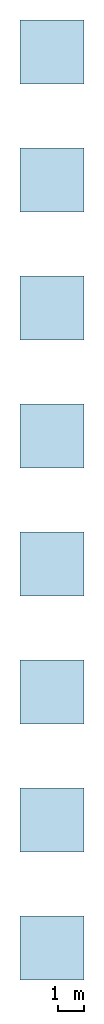
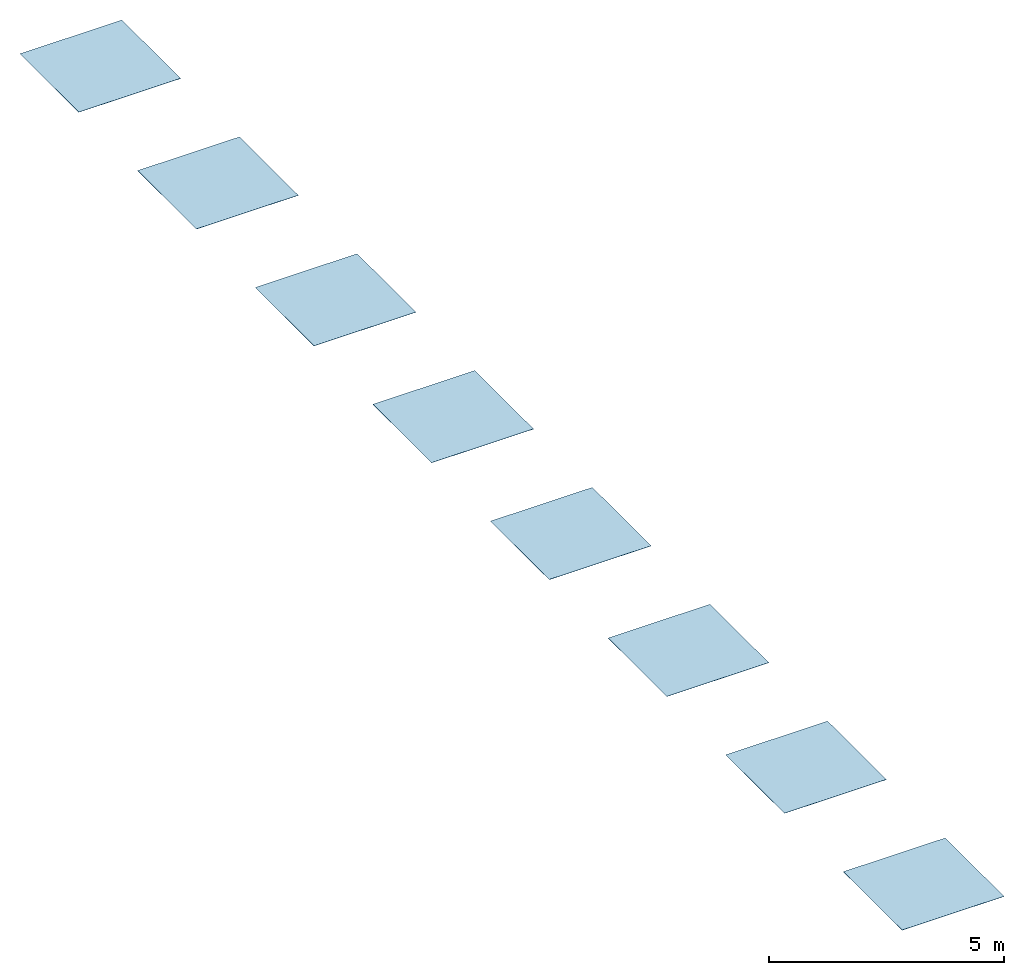
# Not in any storey: 8 slabs.
"""IFC2X3 building model written with IfcOpenShell, lengths in millimetres."""

from ifc_helpers import new_model, si_unit, frame, frame_2d, origin, origin_with_axes, origin_2d, place, context, project, spatial, rectangle, extrude, material, layer, layer_set, layer_usage, type_object, element, save


model = new_model("IFC2X3")

# Units and contexts
model_context = context("Model", 3, precision=1e-05, world=origin())
plan_context = context("Plan", 2, precision=1e-05, world=origin_2d())
ifc_project = project(units=[si_unit("LENGTHUNIT", "METRE", prefix="MILLI"), si_unit("AREAUNIT", "SQUARE_METRE"), si_unit("VOLUMEUNIT", "CUBIC_METRE"), si_unit("SOLIDANGLEUNIT", "STERADIAN"), si_unit("PLANEANGLEUNIT", "RADIAN"), si_unit("MASSUNIT", "GRAM"), si_unit("TIMEUNIT", "SECOND"), si_unit("THERMODYNAMICTEMPERATUREUNIT", "DEGREE_CELSIUS"), si_unit("LUMINOUSINTENSITYUNIT", "LUMEN")], contexts=[model_context, plan_context])

# Site, building
site_placement = place(None, frame((0.0, 0.0, 0.0), z_axis=(0.0, 1.0, 0.0), x_axis=(0.0, 0.0, 1.0)))
site = spatial("IfcSite", under=ifc_project, at=site_placement, CompositionType="ELEMENT")
building_placement = place(site_placement, frame((0.0, 0.0, 0.0), z_axis=(0.0, 1.0, 0.0), x_axis=(0.0, 0.0, 1.0)))
building = spatial("IfcBuilding", under=site, at=building_placement, Name="Default building", CompositionType="ELEMENT")

# Slabs
ifc_material_1 = material()
ifc_layer_1 = layer(ifc_material_1, 5.0, ventilated=False)
ifc_layer_set_1 = layer_set([ifc_layer_1])
ifc_layer_usage_1 = layer_usage(ifc_layer_set_1, "AXIS3", "NEGATIVE", 0.0)
slab_type_1 = type_object("IfcSlabType", PredefinedType="ROOF", material=ifc_layer_set_1)
slab_1_placement = place(None, origin())
element("IfcSlab", 1, at=slab_1_placement, inside=building, type_object=slab_type_1, material=ifc_layer_usage_1, PredefinedType="ROOF", context=model_context, shape_type="SweptSolid", body=[
    extrude(rectangle(XDim=2500.0, YDim=2500.0, at=frame_2d((1250.0, 1250.0))), origin_with_axes(), (0.0, 0.0, 1.0), 5.0),
])
ifc_material_2 = material()
ifc_layer_2 = layer(ifc_material_2, 5.0, ventilated=False)
ifc_layer_set_2 = layer_set([ifc_layer_2])
ifc_layer_usage_2 = layer_usage(ifc_layer_set_2, "AXIS3", "NEGATIVE", 0.0)
slab_type_2 = type_object("IfcSlabType", PredefinedType="ROOF", material=ifc_layer_set_2)
slab_2_placement = place(None, frame((0.0, 5000.0, 0.0)))
element("IfcSlab", 2, at=slab_2_placement, inside=building, type_object=slab_type_2, material=ifc_layer_usage_2, PredefinedType="ROOF", context=model_context, shape_type="SweptSolid", body=[
    extrude(rectangle(XDim=2500.0, YDim=2500.0, at=frame_2d((1250.0, 1250.0))), origin_with_axes(), (0.0, 0.0, 1.0), 5.0),
])
ifc_material_3 = material()
ifc_layer_3 = layer(ifc_material_3, 5.0, ventilated=False)
ifc_layer_set_3 = layer_set([ifc_layer_3])
ifc_layer_usage_3 = layer_usage(ifc_layer_set_3, "AXIS3", "NEGATIVE", 0.0)
slab_type_3 = type_object("IfcSlabType", PredefinedType="ROOF", material=ifc_layer_set_3)
slab_3_placement = place(None, frame((0.0, 10000.0, 0.0)))
element("IfcSlab", 3, at=slab_3_placement, inside=building, type_object=slab_type_3, material=ifc_layer_usage_3, PredefinedType="ROOF", context=model_context, shape_type="SweptSolid", body=[
    extrude(rectangle(XDim=2500.0, YDim=2500.0, at=frame_2d((1250.0, 1250.0))), origin_with_axes(), (0.0, 0.0, 1.0), 5.0),
])
ifc_material_4 = material()
ifc_layer_4 = layer(ifc_material_4, 5.0, ventilated=False)
ifc_layer_set_4 = layer_set([ifc_layer_4])
ifc_layer_usage_4 = layer_usage(ifc_layer_set_4, "AXIS3", "NEGATIVE", 0.0)
slab_type_4 = type_object("IfcSlabType", PredefinedType="ROOF", material=ifc_layer_set_4)
slab_4_placement = place(None, frame((0.0, 15000.0, 0.0)))
element("IfcSlab", 4, at=slab_4_placement, inside=building, type_object=slab_type_4, material=ifc_layer_usage_4, PredefinedType="ROOF", context=model_context, shape_type="SweptSolid", body=[
    extrude(rectangle(XDim=2500.0, YDim=2500.0, at=frame_2d((1250.0, 1250.0))), origin_with_axes(), (0.0, 0.0, 1.0), 5.0),
])
ifc_material_5 = material()
ifc_layer_5 = layer(ifc_material_5, 5.0, ventilated=False)
ifc_layer_set_5 = layer_set([ifc_layer_5])
ifc_layer_usage_5 = layer_usage(ifc_layer_set_5, "AXIS3", "NEGATIVE", 0.0)
slab_type_5 = type_object("IfcSlabType", PredefinedType="ROOF", material=ifc_layer_set_5)
slab_5_placement = place(None, frame((0.0, 20000.0, 0.0)))
element("IfcSlab", 5, at=slab_5_placement, inside=building, type_object=slab_type_5, material=ifc_layer_usage_5, PredefinedType="ROOF", context=model_context, shape_type="SweptSolid", body=[
    extrude(rectangle(XDim=2500.0, YDim=2500.0, at=frame_2d((1250.0, 1250.0))), origin_with_axes(), (0.0, 0.0, 1.0), 5.0),
])
ifc_material_6 = material()
ifc_layer_6 = layer(ifc_material_6, 5.0, ventilated=False)
ifc_layer_set_6 = layer_set([ifc_layer_6])
ifc_layer_usage_6 = layer_usage(ifc_layer_set_6, "AXIS3", "NEGATIVE", 0.0)
slab_type_6 = type_object("IfcSlabType", PredefinedType="ROOF", material=ifc_layer_set_6)
slab_6_placement = place(None, frame((0.0, 25000.0, 0.0)))
element("IfcSlab", 6, at=slab_6_placement, inside=building, type_object=slab_type_6, material=ifc_layer_usage_6, PredefinedType="ROOF", context=model_context, shape_type="SweptSolid", body=[
    extrude(rectangle(XDim=2500.0, YDim=2500.0, at=frame_2d((1250.0, 1250.0))), origin_with_axes(), (0.0, 0.0, 1.0), 5.0),
])
ifc_material_7 = material()
ifc_layer_7 = layer(ifc_material_7, 5.0, ventilated=False)
ifc_layer_set_7 = layer_set([ifc_layer_7])
ifc_layer_usage_7 = layer_usage(ifc_layer_set_7, "AXIS3", "NEGATIVE", 0.0)
slab_type_7 = type_object("IfcSlabType", PredefinedType="ROOF", material=ifc_layer_set_7)
slab_7_placement = place(None, frame((0.0, 30000.0, 0.0)))
element("IfcSlab", 7, at=slab_7_placement, inside=building, type_object=slab_type_7, material=ifc_layer_usage_7, PredefinedType="ROOF", context=model_context, shape_type="SweptSolid", body=[
    extrude(rectangle(XDim=2500.0, YDim=2500.0, at=frame_2d((1250.0, 1250.0))), origin_with_axes(), (0.0, 0.0, 1.0), 5.0),
])
ifc_material_8 = material()
ifc_layer_8 = layer(ifc_material_8, 5.0, ventilated=False)
ifc_layer_set_8 = layer_set([ifc_layer_8])
ifc_layer_usage_8 = layer_usage(ifc_layer_set_8, "AXIS3", "NEGATIVE", 0.0)
slab_type_8 = type_object("IfcSlabType", PredefinedType="ROOF", material=ifc_layer_set_8)
slab_8_placement = place(None, frame((0.0, 35000.0, 0.0)))
element("IfcSlab", 8, at=slab_8_placement, inside=building, type_object=slab_type_8, material=ifc_layer_usage_8, PredefinedType="ROOF", context=model_context, shape_type="SweptSolid", body=[
    extrude(rectangle(XDim=2500.0, YDim=2500.0, at=frame_2d((1250.0, 1250.0))), origin_with_axes(), (0.0, 0.0, 1.0), 5.0),
])

save(model, "model.ifc")
